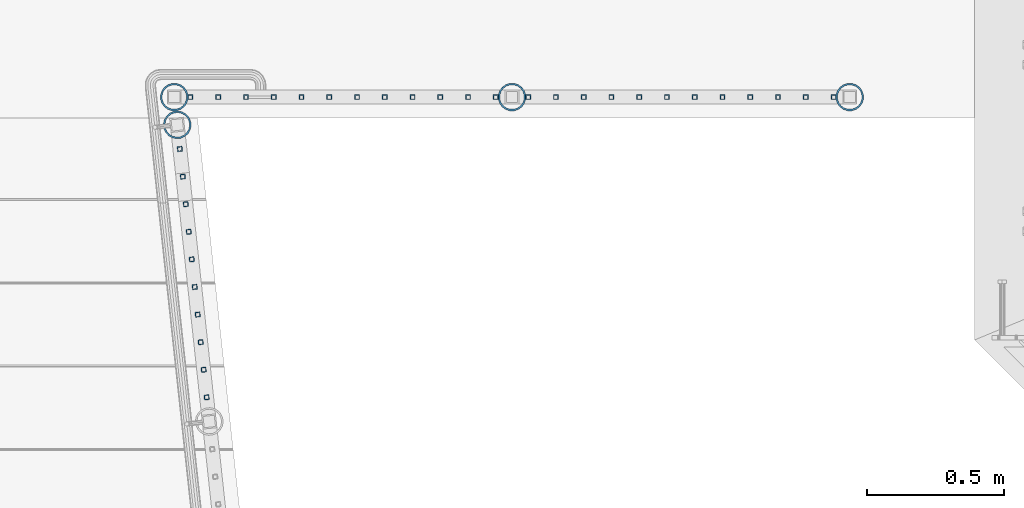
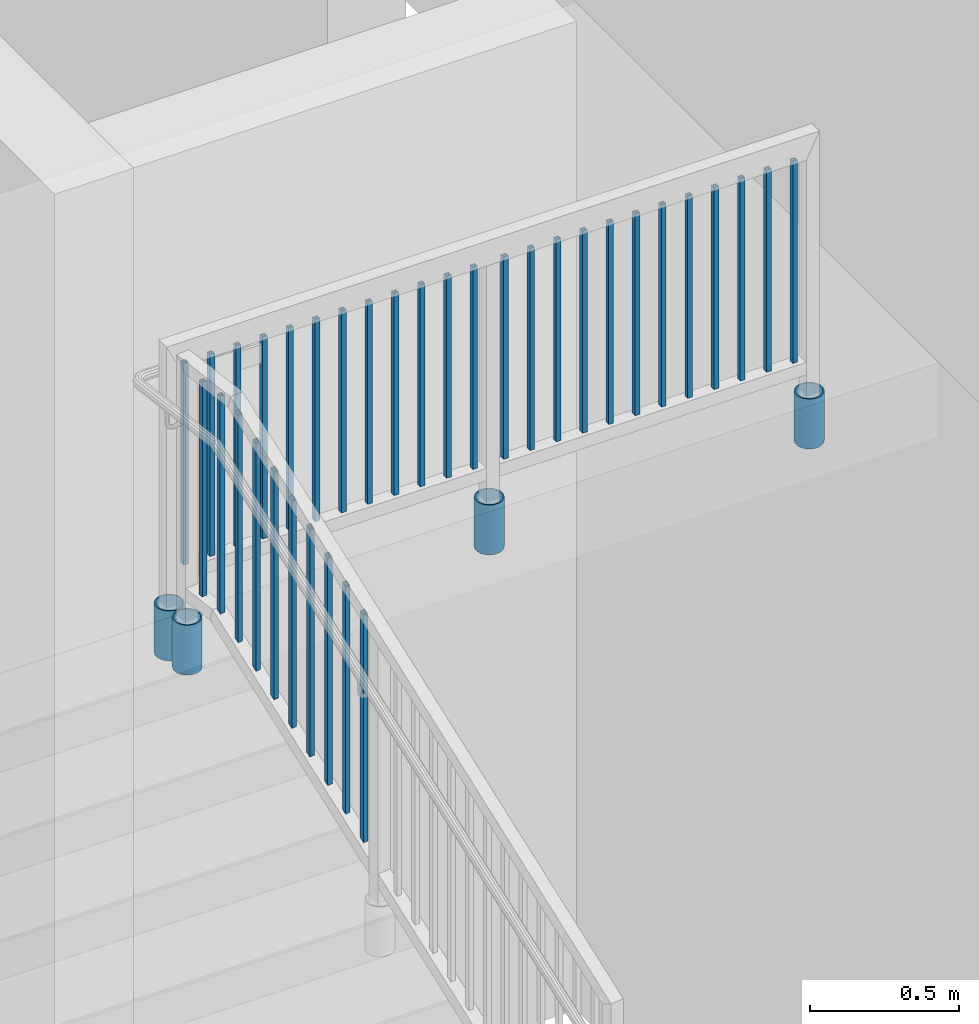
# One storey, part 142 of 975: 38 columns.
"""IFC2X3 building model written with IfcOpenShell, lengths in millimetres."""

from ifc_helpers import new_model, si_unit, frame, origin_with_axes, place, context, subcontext, project, spatial, faceted_brep, material, type_object, element, save


model = new_model("IFC2X3")

# Units and contexts
model_context = context("Model", 3, precision=1e-05, world=origin_with_axes())
body_context = subcontext(model_context, "Body", "Model", "MODEL_VIEW")
ifc_project = project(units=[si_unit("LENGTHUNIT", "METRE", prefix="MILLI"), si_unit("AREAUNIT", "SQUARE_METRE"), si_unit("VOLUMEUNIT", "CUBIC_METRE"), si_unit("MASSUNIT", "GRAM", prefix="KILO"), si_unit("TIMEUNIT", "SECOND"), si_unit("PLANEANGLEUNIT", "RADIAN"), si_unit("SOLIDANGLEUNIT", "STERADIAN"), si_unit("THERMODYNAMICTEMPERATUREUNIT", "DEGREE_CELSIUS"), si_unit("LUMINOUSINTENSITYUNIT", "LUMEN")], contexts=[model_context])

# Site, building, storey
site_placement = place(None, origin_with_axes())
site = spatial("IfcSite", under=ifc_project, at=site_placement, CompositionType="ELEMENT")
building_placement = place(site_placement, origin_with_axes())
building = spatial("IfcBuilding", under=site, at=building_placement, Name="Undefined", CompositionType="ELEMENT")
storey_placement = place(building_placement, origin_with_axes())
storey = spatial("IfcBuildingStorey", under=building, at=storey_placement, Name="Undefined", CompositionType="ELEMENT", Elevation=0.0)

# Columns
ifc_material_1 = material()
column_type_1 = type_object("IfcColumnType", Name="HSS3/4X3/4X.120_TUBES", PredefinedType="NOTDEFINED")
column_1_placement = place(storey_placement, frame((-893.043869114453, 3137.33905229593, 4203.33690920319), z_axis=(-0.107163682972125, 0.994241391741387, -1.51279482452082e-08), x_axis=(0.0, 0.0, 1.0)))
element("IfcColumn", 1, at=column_1_placement, inside=storey, type_object=column_type_1, material=ifc_material_1, Name="PICKET", ObjectType="HSS3/4X3/4X.120_TUBES", context=body_context, shape_type="Brep", body=[
    faceted_brep([(51.1631046552238, 6.34999999999991, -6.35000000000855), (51.1631046600623, -6.34999999999991, -6.35000000000855), (927.463079106175, -6.34999999999991, -6.3500000001477), (927.463079101335, 6.34999999999991, -6.3500000001477), (51.1630993403815, -6.34999999999991, 6.34999999999172), (927.463078498194, -6.34999999999991, 6.34999999985257), (51.1630993355429, 6.34999999999991, 6.34999999999172), (927.463078493354, 6.34999999999991, 6.34999999985257), (51.1631059839347, 9.52500000000009, -9.52500000000873), (51.1630980044138, 9.52500000000009, 9.52499999999191), (927.463078340149, 9.52500000000009, 9.5249999998523), (927.46307925212, 9.52500000000009, -9.52500000014743), (51.1630980116715, -9.52500000000009, 9.52499999999191), (927.463078347408, -9.52500000000009, 9.5249999998523), (51.1631059911924, -9.52500000000009, -9.52500000000873), (927.463079259379, -9.52500000000009, -9.52500000014743)], [[[0, 1, 2, 3]], [[1, 4, 5, 2]], [[4, 6, 7, 5]], [[6, 0, 3, 7]], [[8, 9, 10, 11]], [[9, 12, 13, 10]], [[12, 14, 15, 13]], [[14, 8, 11, 15]], [[13, 15, 11, 10], [5, 7, 3, 2]], [[14, 12, 9, 8], [6, 4, 1, 0]]]),
])
column_2_placement = place(storey_placement, frame((-882.156825510756, 3036.33145302633, 4203.33691042617), z_axis=(-0.107163682972125, 0.994241391741387, -1.51279482452082e-08), x_axis=(0.0, 0.0, 1.0)))
element("IfcColumn", 2, at=column_2_placement, inside=storey, type_object=column_type_1, material=ifc_material_1, Name="PICKET", ObjectType="HSS3/4X3/4X.120_TUBES", context=body_context, shape_type="Brep", body=[
    faceted_brep([(40.1041543496849, 6.34999999999991, -6.35000000000855), (40.1041545719772, -6.35000000000014, -6.35000000000628), (927.463079106175, -6.34999999999991, -6.3500000001477), (927.463079101335, 6.34999999999991, -6.3500000001477), (47.5124881750762, -6.3499999999998, 6.34999999999445), (927.463078498194, -6.34999999999991, 6.34999999985257), (47.5124879527839, 6.35000000000048, 6.34999999999309), (927.463078493354, 6.34999999999991, 6.34999999985257), (38.2520708933371, 9.52499999999975, -9.52500000000828), (49.364571297986, 9.52500000000055, 9.52499999999236), (927.463078340149, 9.52500000000009, 9.5249999998523), (927.46307925212, 9.52500000000009, -9.52500000014743), (49.364571631424, -9.52499999999964, 9.52499999999509), (927.463078347408, -9.52500000000009, 9.5249999998523), (38.2520712267751, -9.52500000000043, -9.52500000000555), (927.463079259379, -9.52500000000009, -9.52500000014743)], [[[0, 1, 2, 3]], [[1, 4, 5, 2]], [[4, 6, 7, 5]], [[6, 0, 3, 7]], [[8, 9, 10, 11]], [[9, 12, 13, 10]], [[12, 14, 15, 13]], [[14, 8, 11, 15]], [[13, 15, 11, 10], [5, 7, 3, 2]], [[14, 12, 9, 8], [6, 4, 1, 0]]]),
])
for number, where, z_axis, x_axis, name in (
    (3, (-871.269781887117, 2935.32385357171, 4187.88286216125), (-0.107163682972125, 0.994241391741387, -1.51279482452082e-08), (0.0, 0.0, 1.0), "PICKET"),
    (4, (-860.382738206991, 2834.31625359302, 4128.62049317313), (-0.107163682972125, 0.994241391741387, -1.51279482452082e-08), (0.0, 0.0, 1.0), "PICKET"),
    (5, (-849.495694526905, 2733.3086536147, 4069.35812418497), (-0.107163682972125, 0.994241391741387, -1.51279482452082e-08), (0.0, 0.0, 1.0), "PICKET"),
    (6, (-838.608650846774, 2632.30105363596, 4010.09575519681), (-0.107163682972125, 0.994241391741387, -1.51279482452082e-08), (0.0, 0.0, 1.0), "PICKET"),
    (7, (-827.721607166643, 2531.29345365722, 3950.83338620865), (-0.107163682972125, 0.994241391741387, -1.51279482452082e-08), (0.0, 0.0, 1.0), "PICKET"),
    (8, (-816.834563486512, 2430.28585367849, 3891.5710172205), (-0.107163682972125, 0.994241391741387, -1.51279482452082e-08), (0.0, 0.0, 1.0), "PICKET"),
    (9, (-805.947519806381, 2329.27825369975, 3832.30864823234), (-0.107163682972125, 0.994241391741387, -1.51279482452082e-08), (0.0, 0.0, 1.0), "PICKET"),
    (10, (-795.06047612625, 2228.27065372101, 3773.04627924418), (-0.107163682972125, 0.994241391741387, -1.51279482452082e-08), (0.0, 0.0, 1.0), "PICKET"),
):
    element("IfcColumn", number, at=place(storey_placement, frame(where, z_axis=z_axis, x_axis=x_axis)), inside=storey, type_object=column_type_1, material=ifc_material_1, Name=name, ObjectType="HSS3/4X3/4X.120_TUBES", context=body_context, shape_type="Brep", body=[
        faceted_brep([(-3.70416645998739, 6.34999999999991, -6.34999999999945), (-3.70416623769415, -6.34999999999991, -6.34999999999945), (923.75891709344, -6.34999999999991, -6.35000000014634), (923.758916871147, 6.34999999999991, -6.35000000014634), (3.70416736539664, -6.34999999999991, 6.349999999999), (931.167250696531, -6.34999999999991, 6.34999999985212), (3.70416714310431, 6.34999999999991, 6.349999999999), (931.167250474238, 6.34999999999991, 6.34999999985212), (-5.5562499163334, 9.52500000000009, -9.52499999999964), (5.5562504883037, 9.52500000000009, 9.52499999999918), (933.019333819438, 9.52500000000009, 9.5249999998523), (921.906833414801, 9.52500000000009, -9.52500000014652), (5.55625082174265, -9.52500000000009, 9.52499999999918), (933.019334152877, -9.52500000000009, 9.5249999998523), (-5.55624958289354, -9.52500000000009, -9.52499999999964), (921.90683374824, -9.52500000000009, -9.52500000014652)], [[[0, 1, 2, 3]], [[1, 4, 5, 2]], [[4, 6, 7, 5]], [[6, 0, 3, 7]], [[8, 9, 10, 11]], [[9, 12, 13, 10]], [[12, 14, 15, 13]], [[14, 8, 11, 15]], [[13, 15, 11, 10], [5, 7, 3, 2]], [[14, 12, 9, 8], [6, 4, 1, 0]]]),
    ])
for number, where, z_axis, x_axis, name in (
    (11, (1499.61038437075, 3327.40036795435, 4254.50001855985), (1.0, 0.0, 0.0), (0.0, 0.0, 1.0), "PICKET"),
    (12, (1398.01038437075, 3327.40036795435, 4254.50001855985), (1.0, 0.0, 0.0), (0.0, 0.0, 1.0), "PICKET"),
    (13, (1296.41038437075, 3327.40036795435, 4254.50001855985), (1.0, 0.0, 0.0), (0.0, 0.0, 1.0), "PICKET"),
    (14, (1194.81038437075, 3327.40036795435, 4254.50001855985), (1.0, 0.0, 0.0), (0.0, 0.0, 1.0), "PICKET"),
    (15, (1093.21038437075, 3327.40036795435, 4254.50001855985), (1.0, 0.0, 0.0), (0.0, 0.0, 1.0), "PICKET"),
    (16, (991.610384370745, 3327.40036795435, 4254.50001855985), (1.0, 0.0, 0.0), (0.0, 0.0, 1.0), "PICKET"),
    (17, (890.010384370746, 3327.40036795435, 4254.50001855985), (1.0, 0.0, 0.0), (0.0, 0.0, 1.0), "PICKET"),
    (18, (788.410384370746, 3327.40036795435, 4254.50001855985), (1.0, 0.0, 0.0), (0.0, 0.0, 1.0), "PICKET"),
    (19, (686.810384370746, 3327.40036795435, 4254.50001855985), (1.0, 0.0, 0.0), (0.0, 0.0, 1.0), "PICKET"),
    (20, (585.210384370745, 3327.40036795435, 4254.50001855985), (1.0, 0.0, 0.0), (0.0, 0.0, 1.0), "PICKET"),
    (21, (483.610384370746, 3327.40036795435, 4254.50001855985), (1.0, 0.0, 0.0), (0.0, 0.0, 1.0), "PICKET"),
    (22, (382.010384370746, 3327.40036795435, 4254.50001855985), (1.0, 0.0, 0.0), (0.0, 0.0, 1.0), "PICKET"),
    (23, (263.380990660052, 3327.40038657919, 4254.50001844122), (1.0, 0.0, 0.0), (0.0, 0.0, 1.0), "PICKET"),
    (24, (161.780990660037, 3327.40040253042, 4254.50001844122), (1.0, 0.0, 0.0), (0.0, 0.0, 1.0), "PICKET"),
    (25, (60.1809906600373, 3327.40040253042, 4254.50001844122), (1.0, 0.0, 0.0), (0.0, 0.0, 1.0), "PICKET"),
    (26, (-41.4190093399627, 3327.40040253042, 4254.50001844122), (1.0, 0.0, 0.0), (0.0, 0.0, 1.0), "PICKET"),
    (27, (-143.019009339963, 3327.40040253042, 4254.50001844122), (1.0, 0.0, 0.0), (0.0, 0.0, 1.0), "PICKET"),
    (28, (-244.619009339963, 3327.40040253042, 4254.50001844122), (1.0, 0.0, 0.0), (0.0, 0.0, 1.0), "PICKET"),
    (29, (-346.219009339963, 3327.40040253042, 4254.50001844122), (1.0, 0.0, 0.0), (0.0, 0.0, 1.0), "PICKET"),
    (30, (-447.819009339963, 3327.40040253042, 4254.50001844122), (1.0, 0.0, 0.0), (0.0, 0.0, 1.0), "PICKET"),
    (31, (-549.419009339963, 3327.40040253042, 4254.50001844122), (1.0, 0.0, 0.0), (0.0, 0.0, 1.0), "PICKET"),
    (32, (-651.019009339963, 3327.40040253042, 4254.50001844122), (1.0, 0.0, 0.0), (0.0, 0.0, 1.0), "PICKET"),
    (33, (-752.619009339963, 3327.40040253042, 4254.50001844122), (1.0, 0.0, 0.0), (0.0, 0.0, 1.0), "PICKET"),
    (34, (-854.219009339963, 3327.40040253042, 4254.50001844122), (1.0, 0.0, 0.0), (0.0, 0.0, 1.0), "PICKET"),
):
    element("IfcColumn", number, at=place(storey_placement, frame(where, z_axis=z_axis, x_axis=x_axis)), inside=storey, type_object=column_type_1, material=ifc_material_1, Name=name, ObjectType="HSS3/4X3/4X.120_TUBES", context=body_context, shape_type="Brep", body=[
        faceted_brep([(0.0, 6.34999999998763, -6.34999999998763), (0.0, -6.35000000000582, -6.34999999998763), (825.49997943247, -6.35000000000582, -6.34999999998763), (825.49997943247, 6.34999999998763, -6.34999999998763), (0.0, -6.34999999998763, 6.34999999998763), (825.49997943247, -6.34999999998763, 6.34999999998763), (0.0, 6.35000000000946, 6.34999999998763), (825.49997943247, 6.35000000000946, 6.34999999998763), (0.0, 9.52499999997963, -9.52499999997963), (0.0, 9.52500000000873, 9.5249999999869), (825.49997943247, 9.52500000000873, 9.5249999999869), (825.49997943247, 9.52499999997963, -9.52499999997963), (0.0, -9.52499999997963, 9.52499999998327), (825.49997943247, -9.52499999997963, 9.52499999998327), (0.0, -9.52500000000873, -9.5249999999869), (825.49997943247, -9.52500000000873, -9.5249999999869)], [[[0, 1, 2, 3]], [[1, 4, 5, 2]], [[4, 6, 7, 5]], [[6, 0, 3, 7]], [[8, 9, 10, 11]], [[9, 12, 13, 10]], [[12, 14, 15, 13]], [[14, 8, 11, 15]], [[13, 15, 11, 10], [5, 7, 3, 2]], [[14, 12, 9, 8], [6, 4, 1, 0]]]),
    ])
ifc_material_2 = material(Name="STEEL/A53")
column_type_2 = type_object("IfcColumnType", Name="PIPE3-1/2STD", PredefinedType="NOTDEFINED")
column_3_placement = place(storey_placement, frame((-902.57861743711, 3225.80035230631, 3911.59996494345), z_axis=(-0.778811015080024, 0.627258641064452, -9.08472520677606e-09), x_axis=(0.0, 0.0, 1.0)))
element("IfcColumn", 35, at=column_3_placement, inside=storey, type_object=column_type_2, material=ifc_material_2, ObjectType="PIPE3-1/2STD", context=body_context, shape_type="Brep", body=[
    faceted_brep([(0.0, -45.0595999999932, 1.45519152283669e-11), (0.0, -42.8542262016344, 13.924182159768), (203.199999999991, -42.8542262017145, 13.9241821598171), (203.19999999999, -45.0596000000478, 5.82076609134674e-11), (0.0, -36.45398215971, 26.4853683542424), (203.199999999993, -36.45398215981, 26.4853683542988), (0.0, -26.4853683541623, 36.45398215979), (203.199999999995, -26.4853683542788, 36.4539821598537), (0.0, -13.9241821596988, 42.8542262017108), (203.199999999998, -13.9241821598262, 42.8542262017836), (0.0, 3.63797880709171e-11, 45.0596000000514), (203.2, -9.27684595808387e-11, 45.0596000001387), (0.0, 13.9241821597716, 42.8542262017036), (203.200000000003, 13.9241821596443, 42.8542262017927), (0.0, 26.4853683542242, 36.4539821597718), (203.200000000006, 26.4853683541096, 36.4539821598701), (0.0, 36.4539821597537, 26.4853683542206), (203.200000000008, 36.4539821596554, 26.4853683543224), (0.0, 42.8542262016563, 13.9241821597425), (203.200000000009, 42.8542262015817, 13.9241821598443), (0.0, 45.0595999999932, -1.09139364212751e-11), (203.200000000009, 45.0595999999423, 8.9130480773747e-11), (0.0, 42.8542262016344, -13.9241821597643), (203.200000000008, 42.854226201609, -13.9241821596697), (0.0, 36.45398215971, -26.4853683542387), (203.200000000007, 36.4539821597045, -26.4853683541514), (0.0, 26.4853683541623, -36.4539821597864), (203.200000000004, 26.4853683541733, -36.4539821597064), (0.0, 13.9241821596988, -42.8542262017072), (203.200000000002, 13.9241821597225, -42.8542262016381), (0.0, -3.63797880709171e-11, -45.0596000000478), (203.199999999999, -9.09494701772928e-12, -45.0595999999914), (0.0, -13.9241821597716, -42.8542262016963), (203.199999999996, -13.9241821597479, -42.8542262016472), (0.0, -26.4853683542242, -36.4539821597682), (203.199999999993, -26.4853683542133, -36.4539821597227), (0.0, -36.4539821597537, -26.4853683542169), (203.199999999992, -36.4539821597609, -26.4853683541751), (0.0, -42.8542262016563, -13.9241821597352), (203.199999999991, -42.8542262016872, -13.924182159697), (0.0, -50.799999999992, 1.81898940354586e-11), (0.0, -48.3136710278013, -15.6980633142484), (203.199999999989, -48.313671027825, -15.6980633142139), (203.199999999989, -50.8000000000466, 5.63886715099216e-11), (0.0, -41.0980633142644, -29.8594908164741), (203.19999999999, -41.0980633142663, -29.8594908164414), (0.0, -29.859490816485, -41.0980633142826), (203.199999999993, -29.8594908164687, -41.0980633142426), (0.0, -15.6980633142848, -48.313671027845), (203.199999999995, -15.6980633142539, -48.313671027794), (0.0, -4.36557456851006e-11, -50.8000000000575), (203.199999999998, -7.27595761418343e-12, -50.7999999999993), (0.0, 15.6980633142011, -48.3136710278523), (203.200000000002, 15.6980633142375, -48.3136710277831), (0.0, 29.8594908164159, -41.0980633143045), (203.200000000005, 29.8594908164378, -41.0980633142226), (0.0, 41.0980633142135, -29.8594908165032), (203.200000000008, 41.0980633142171, -29.8594908164141), (0.0, 48.3136710277722, -15.6980633142775), (203.200000000009, 48.3136710277504, -15.6980633141811), (0.0, 50.799999999992, -1.45519152283669e-11), (203.20000000001, 50.7999999999411, 9.09494701772928e-11), (0.0, 48.313671027794, 15.6980633142521), (203.20000000001, 48.3136710277213, 15.6980633143594), (0.0, 41.0980633142644, 29.8594908164814), (203.200000000008, 41.0980633141626, 29.8594908165887), (0.0, 29.859490816485, 41.0980633142863), (203.200000000007, 29.8594908163632, 41.0980633143899), (0.0, 15.6980633142848, 48.3136710278486), (203.200000000004, 15.6980633141484, 48.3136710279414), (0.0, 4.00177668780088e-11, 50.8000000000611), (203.200000000001, -9.82254277914762e-11, 50.8000000001466), (0.0, -15.6980633142011, 48.3136710278559), (203.199999999997, -15.698063314343, 48.3136710279305), (0.0, -29.8594908164159, 41.0980633143081), (203.199999999994, -29.8594908165433, 41.0980633143681), (0.0, -41.0980633142171, 29.8594908165069), (203.199999999992, -41.0980633143226, 29.8594908165596), (0.0, -48.3136710277722, 15.6980633142812), (203.19999999999, -48.3136710278559, 15.6980633143285)], [[[0, 1, 2, 3]], [[1, 4, 5, 2]], [[4, 6, 7, 5]], [[6, 8, 9, 7]], [[8, 10, 11, 9]], [[10, 12, 13, 11]], [[12, 14, 15, 13]], [[14, 16, 17, 15]], [[16, 18, 19, 17]], [[18, 20, 21, 19]], [[20, 22, 23, 21]], [[22, 24, 25, 23]], [[24, 26, 27, 25]], [[26, 28, 29, 27]], [[28, 30, 31, 29]], [[30, 32, 33, 31]], [[32, 34, 35, 33]], [[34, 36, 37, 35]], [[36, 38, 39, 37]], [[38, 0, 3, 39]], [[40, 41, 42, 43]], [[41, 44, 45, 42]], [[44, 46, 47, 45]], [[46, 48, 49, 47]], [[48, 50, 51, 49]], [[50, 52, 53, 51]], [[52, 54, 55, 53]], [[54, 56, 57, 55]], [[56, 58, 59, 57]], [[58, 60, 61, 59]], [[60, 62, 63, 61]], [[62, 64, 65, 63]], [[64, 66, 67, 65]], [[66, 68, 69, 67]], [[68, 70, 71, 69]], [[70, 72, 73, 71]], [[72, 74, 75, 73]], [[74, 76, 77, 75]], [[76, 78, 79, 77]], [[78, 40, 43, 79]], [[45, 47, 49, 51, 53, 55, 57, 59, 61, 63, 65, 67, 69, 71, 73, 75, 77, 79, 43, 42], [5, 7, 9, 11, 13, 15, 17, 19, 21, 23, 25, 27, 29, 31, 33, 35, 37, 39, 3, 2]], [[78, 76, 74, 72, 70, 68, 66, 64, 62, 60, 58, 56, 54, 52, 50, 48, 46, 44, 41, 40], [38, 36, 34, 32, 30, 28, 26, 24, 22, 20, 18, 16, 14, 12, 10, 8, 6, 4, 1, 0]]]),
])
column_4_placement = place(storey_placement, frame((1558.92499396022, 3327.43642318416, 3911.60001649977), z_axis=(-0.707106781186601, 0.707106781186494, 2.36468622460961e-14), x_axis=(0.0, 0.0, 1.0)))
element("IfcColumn", 36, at=column_4_placement, inside=storey, type_object=column_type_2, material=ifc_material_2, ObjectType="PIPE3-1/2STD", context=body_context, shape_type="Brep", body=[
    faceted_brep([(0.0, -45.0595999999932, 1.45519152283669e-11), (0.0, -42.8542262016344, 13.924182159768), (203.199999999991, -42.8542262017145, 13.9241821598171), (203.19999999999, -45.0596000000478, 5.82076609134674e-11), (0.0, -36.45398215971, 26.4853683542424), (203.199999999993, -36.45398215981, 26.4853683542988), (0.0, -26.4853683541623, 36.45398215979), (203.199999999995, -26.4853683542788, 36.4539821598537), (0.0, -13.9241821596988, 42.8542262017108), (203.199999999998, -13.9241821598262, 42.8542262017836), (0.0, 3.63797880709171e-11, 45.0596000000514), (203.2, -9.27684595808387e-11, 45.0596000001387), (0.0, 13.9241821597716, 42.8542262017036), (203.200000000003, 13.9241821596443, 42.8542262017927), (0.0, 26.4853683542242, 36.4539821597718), (203.200000000006, 26.4853683541096, 36.4539821598701), (0.0, 36.4539821597537, 26.4853683542206), (203.200000000008, 36.4539821596554, 26.4853683543224), (0.0, 42.8542262016563, 13.9241821597425), (203.200000000009, 42.8542262015817, 13.9241821598443), (0.0, 45.0595999999932, -1.09139364212751e-11), (203.200000000009, 45.0595999999423, 8.9130480773747e-11), (0.0, 42.8542262016344, -13.9241821597643), (203.200000000008, 42.854226201609, -13.9241821596697), (0.0, 36.45398215971, -26.4853683542387), (203.200000000007, 36.4539821597045, -26.4853683541514), (0.0, 26.4853683541623, -36.4539821597864), (203.200000000004, 26.4853683541733, -36.4539821597064), (0.0, 13.9241821596988, -42.8542262017072), (203.200000000002, 13.9241821597225, -42.8542262016381), (0.0, -3.63797880709171e-11, -45.0596000000478), (203.199999999999, -9.09494701772928e-12, -45.0595999999914), (0.0, -13.9241821597716, -42.8542262016963), (203.199999999996, -13.9241821597479, -42.8542262016472), (0.0, -26.4853683542242, -36.4539821597682), (203.199999999993, -26.4853683542133, -36.4539821597227), (0.0, -36.4539821597537, -26.4853683542169), (203.199999999992, -36.4539821597609, -26.4853683541751), (0.0, -42.8542262016563, -13.9241821597352), (203.199999999991, -42.8542262016872, -13.924182159697), (0.0, -50.799999999992, 1.81898940354586e-11), (0.0, -48.3136710278013, -15.6980633142484), (203.199999999989, -48.313671027825, -15.6980633142139), (203.199999999989, -50.8000000000466, 5.63886715099216e-11), (0.0, -41.0980633142644, -29.8594908164741), (203.19999999999, -41.0980633142663, -29.8594908164414), (0.0, -29.859490816485, -41.0980633142826), (203.199999999993, -29.8594908164687, -41.0980633142426), (0.0, -15.6980633142848, -48.313671027845), (203.199999999995, -15.6980633142539, -48.313671027794), (0.0, -4.36557456851006e-11, -50.8000000000575), (203.199999999998, -7.27595761418343e-12, -50.7999999999993), (0.0, 15.6980633142011, -48.3136710278523), (203.200000000002, 15.6980633142375, -48.3136710277831), (0.0, 29.8594908164159, -41.0980633143045), (203.200000000005, 29.8594908164378, -41.0980633142226), (0.0, 41.0980633142135, -29.8594908165032), (203.200000000008, 41.0980633142171, -29.8594908164141), (0.0, 48.3136710277722, -15.6980633142775), (203.200000000009, 48.3136710277504, -15.6980633141811), (0.0, 50.799999999992, -1.45519152283669e-11), (203.20000000001, 50.7999999999411, 9.09494701772928e-11), (0.0, 48.313671027794, 15.6980633142521), (203.20000000001, 48.3136710277213, 15.6980633143594), (0.0, 41.0980633142644, 29.8594908164814), (203.200000000008, 41.0980633141626, 29.8594908165887), (0.0, 29.859490816485, 41.0980633142863), (203.200000000007, 29.8594908163632, 41.0980633143899), (0.0, 15.6980633142848, 48.3136710278486), (203.200000000004, 15.6980633141484, 48.3136710279414), (0.0, 4.00177668780088e-11, 50.8000000000611), (203.200000000001, -9.82254277914762e-11, 50.8000000001466), (0.0, -15.6980633142011, 48.3136710278559), (203.199999999997, -15.698063314343, 48.3136710279305), (0.0, -29.8594908164159, 41.0980633143081), (203.199999999994, -29.8594908165433, 41.0980633143681), (0.0, -41.0980633142171, 29.8594908165069), (203.199999999992, -41.0980633143226, 29.8594908165596), (0.0, -48.3136710277722, 15.6980633142812), (203.19999999999, -48.3136710278559, 15.6980633143285)], [[[0, 1, 2, 3]], [[1, 4, 5, 2]], [[4, 6, 7, 5]], [[6, 8, 9, 7]], [[8, 10, 11, 9]], [[10, 12, 13, 11]], [[12, 14, 15, 13]], [[14, 16, 17, 15]], [[16, 18, 19, 17]], [[18, 20, 21, 19]], [[20, 22, 23, 21]], [[22, 24, 25, 23]], [[24, 26, 27, 25]], [[26, 28, 29, 27]], [[28, 30, 31, 29]], [[30, 32, 33, 31]], [[32, 34, 35, 33]], [[34, 36, 37, 35]], [[36, 38, 39, 37]], [[38, 0, 3, 39]], [[40, 41, 42, 43]], [[41, 44, 45, 42]], [[44, 46, 47, 45]], [[46, 48, 49, 47]], [[48, 50, 51, 49]], [[50, 52, 53, 51]], [[52, 54, 55, 53]], [[54, 56, 57, 55]], [[56, 58, 59, 57]], [[58, 60, 61, 59]], [[60, 62, 63, 61]], [[62, 64, 65, 63]], [[64, 66, 67, 65]], [[66, 68, 69, 67]], [[68, 70, 71, 69]], [[70, 72, 73, 71]], [[72, 74, 75, 73]], [[74, 76, 77, 75]], [[76, 78, 79, 77]], [[78, 40, 43, 79]], [[45, 47, 49, 51, 53, 55, 57, 59, 61, 63, 65, 67, 69, 71, 73, 75, 77, 79, 43, 42], [5, 7, 9, 11, 13, 15, 17, 19, 21, 23, 25, 27, 29, 31, 33, 35, 37, 39, 3, 2]], [[78, 76, 74, 72, 70, 68, 66, 64, 62, 60, 58, 56, 54, 52, 50, 48, 46, 44, 41, 40], [38, 36, 34, 32, 30, 28, 26, 24, 22, 20, 18, 16, 14, 12, 10, 8, 6, 4, 1, 0]]]),
])
column_5_placement = place(storey_placement, frame((322.695797111396, 3327.40039056697, 3911.60001649977), z_axis=(-0.707106781186601, 0.707106781186494, 2.36468622460961e-14), x_axis=(0.0, 0.0, 1.0)))
element("IfcColumn", 37, at=column_5_placement, inside=storey, type_object=column_type_2, material=ifc_material_2, ObjectType="PIPE3-1/2STD", context=body_context, shape_type="Brep", body=[
    faceted_brep([(0.0, -45.0595999999932, 1.45519152283669e-11), (0.0, -42.8542262016344, 13.924182159768), (203.199999999991, -42.8542262017145, 13.9241821598171), (203.19999999999, -45.0596000000478, 5.82076609134674e-11), (0.0, -36.45398215971, 26.4853683542424), (203.199999999993, -36.45398215981, 26.4853683542988), (0.0, -26.4853683541623, 36.45398215979), (203.199999999995, -26.4853683542788, 36.4539821598537), (0.0, -13.9241821596988, 42.8542262017108), (203.199999999998, -13.9241821598262, 42.8542262017836), (0.0, 3.63797880709171e-11, 45.0596000000514), (203.2, -9.27684595808387e-11, 45.0596000001387), (0.0, 13.9241821597716, 42.8542262017036), (203.200000000003, 13.9241821596443, 42.8542262017927), (0.0, 26.4853683542242, 36.4539821597718), (203.200000000006, 26.4853683541096, 36.4539821598701), (0.0, 36.4539821597537, 26.4853683542206), (203.200000000008, 36.4539821596554, 26.4853683543224), (0.0, 42.8542262016563, 13.9241821597425), (203.200000000009, 42.8542262015817, 13.9241821598443), (0.0, 45.0595999999932, -1.09139364212751e-11), (203.200000000009, 45.0595999999423, 8.9130480773747e-11), (0.0, 42.8542262016344, -13.9241821597643), (203.200000000008, 42.854226201609, -13.9241821596697), (0.0, 36.45398215971, -26.4853683542387), (203.200000000007, 36.4539821597045, -26.4853683541514), (0.0, 26.4853683541623, -36.4539821597864), (203.200000000004, 26.4853683541733, -36.4539821597064), (0.0, 13.9241821596988, -42.8542262017072), (203.200000000002, 13.9241821597225, -42.8542262016381), (0.0, -3.63797880709171e-11, -45.0596000000478), (203.199999999999, -9.09494701772928e-12, -45.0595999999914), (0.0, -13.9241821597716, -42.8542262016963), (203.199999999996, -13.9241821597479, -42.8542262016472), (0.0, -26.4853683542242, -36.4539821597682), (203.199999999993, -26.4853683542133, -36.4539821597227), (0.0, -36.4539821597537, -26.4853683542169), (203.199999999992, -36.4539821597609, -26.4853683541751), (0.0, -42.8542262016563, -13.9241821597352), (203.199999999991, -42.8542262016872, -13.924182159697), (0.0, -50.799999999992, 1.81898940354586e-11), (0.0, -48.3136710278013, -15.6980633142484), (203.199999999989, -48.313671027825, -15.6980633142139), (203.199999999989, -50.8000000000466, 5.63886715099216e-11), (0.0, -41.0980633142644, -29.8594908164741), (203.19999999999, -41.0980633142663, -29.8594908164414), (0.0, -29.859490816485, -41.0980633142826), (203.199999999993, -29.8594908164687, -41.0980633142426), (0.0, -15.6980633142848, -48.313671027845), (203.199999999995, -15.6980633142539, -48.313671027794), (0.0, -4.36557456851006e-11, -50.8000000000575), (203.199999999998, -7.27595761418343e-12, -50.7999999999993), (0.0, 15.6980633142011, -48.3136710278523), (203.200000000002, 15.6980633142375, -48.3136710277831), (0.0, 29.8594908164159, -41.0980633143045), (203.200000000005, 29.8594908164378, -41.0980633142226), (0.0, 41.0980633142135, -29.8594908165032), (203.200000000008, 41.0980633142171, -29.8594908164141), (0.0, 48.3136710277722, -15.6980633142775), (203.200000000009, 48.3136710277504, -15.6980633141811), (0.0, 50.799999999992, -1.45519152283669e-11), (203.20000000001, 50.7999999999411, 9.09494701772928e-11), (0.0, 48.313671027794, 15.6980633142521), (203.20000000001, 48.3136710277213, 15.6980633143594), (0.0, 41.0980633142644, 29.8594908164814), (203.200000000008, 41.0980633141626, 29.8594908165887), (0.0, 29.859490816485, 41.0980633142863), (203.200000000007, 29.8594908163632, 41.0980633143899), (0.0, 15.6980633142848, 48.3136710278486), (203.200000000004, 15.6980633141484, 48.3136710279414), (0.0, 4.00177668780088e-11, 50.8000000000611), (203.200000000001, -9.82254277914762e-11, 50.8000000001466), (0.0, -15.6980633142011, 48.3136710278559), (203.199999999997, -15.698063314343, 48.3136710279305), (0.0, -29.8594908164159, 41.0980633143081), (203.199999999994, -29.8594908165433, 41.0980633143681), (0.0, -41.0980633142171, 29.8594908165069), (203.199999999992, -41.0980633143226, 29.8594908165596), (0.0, -48.3136710277722, 15.6980633142812), (203.19999999999, -48.3136710278559, 15.6980633143285)], [[[0, 1, 2, 3]], [[1, 4, 5, 2]], [[4, 6, 7, 5]], [[6, 8, 9, 7]], [[8, 10, 11, 9]], [[10, 12, 13, 11]], [[12, 14, 15, 13]], [[14, 16, 17, 15]], [[16, 18, 19, 17]], [[18, 20, 21, 19]], [[20, 22, 23, 21]], [[22, 24, 25, 23]], [[24, 26, 27, 25]], [[26, 28, 29, 27]], [[28, 30, 31, 29]], [[30, 32, 33, 31]], [[32, 34, 35, 33]], [[34, 36, 37, 35]], [[36, 38, 39, 37]], [[38, 0, 3, 39]], [[40, 41, 42, 43]], [[41, 44, 45, 42]], [[44, 46, 47, 45]], [[46, 48, 49, 47]], [[48, 50, 51, 49]], [[50, 52, 53, 51]], [[52, 54, 55, 53]], [[54, 56, 57, 55]], [[56, 58, 59, 57]], [[58, 60, 61, 59]], [[60, 62, 63, 61]], [[62, 64, 65, 63]], [[64, 66, 67, 65]], [[66, 68, 69, 67]], [[68, 70, 71, 69]], [[70, 72, 73, 71]], [[72, 74, 75, 73]], [[74, 76, 77, 75]], [[76, 78, 79, 77]], [[78, 40, 43, 79]], [[45, 47, 49, 51, 53, 55, 57, 59, 61, 63, 65, 67, 69, 71, 73, 75, 77, 79, 43, 42], [5, 7, 9, 11, 13, 15, 17, 19, 21, 23, 25, 27, 29, 31, 33, 35, 37, 39, 3, 2]], [[78, 76, 74, 72, 70, 68, 66, 64, 62, 60, 58, 56, 54, 52, 50, 48, 46, 44, 41, 40], [38, 36, 34, 32, 30, 28, 26, 24, 22, 20, 18, 16, 14, 12, 10, 8, 6, 4, 1, 0]]]),
])
column_6_placement = place(storey_placement, frame((-913.533791529012, 3327.43681221011, 3911.60001649977), z_axis=(-0.707106781186601, 0.707106781186494, 2.36468622460961e-14), x_axis=(0.0, 0.0, 1.0)))
element("IfcColumn", 38, at=column_6_placement, inside=storey, type_object=column_type_2, material=ifc_material_2, ObjectType="PIPE3-1/2STD", context=body_context, shape_type="Brep", body=[
    faceted_brep([(0.0, -45.0595999999932, 1.45519152283669e-11), (0.0, -42.8542262016344, 13.924182159768), (203.199999999991, -42.8542262017145, 13.9241821598171), (203.19999999999, -45.0596000000478, 5.82076609134674e-11), (0.0, -36.45398215971, 26.4853683542424), (203.199999999993, -36.45398215981, 26.4853683542988), (0.0, -26.4853683541623, 36.45398215979), (203.199999999995, -26.4853683542788, 36.4539821598537), (0.0, -13.9241821596988, 42.8542262017108), (203.199999999998, -13.9241821598262, 42.8542262017836), (0.0, 3.63797880709171e-11, 45.0596000000514), (203.2, -9.27684595808387e-11, 45.0596000001387), (0.0, 13.9241821597716, 42.8542262017036), (203.200000000003, 13.9241821596443, 42.8542262017927), (0.0, 26.4853683542242, 36.4539821597718), (203.200000000006, 26.4853683541096, 36.4539821598701), (0.0, 36.4539821597537, 26.4853683542206), (203.200000000008, 36.4539821596554, 26.4853683543224), (0.0, 42.8542262016563, 13.9241821597425), (203.200000000009, 42.8542262015817, 13.9241821598443), (0.0, 45.0595999999932, -1.09139364212751e-11), (203.200000000009, 45.0595999999423, 8.9130480773747e-11), (0.0, 42.8542262016344, -13.9241821597643), (203.200000000008, 42.854226201609, -13.9241821596697), (0.0, 36.45398215971, -26.4853683542387), (203.200000000007, 36.4539821597045, -26.4853683541514), (0.0, 26.4853683541623, -36.4539821597864), (203.200000000004, 26.4853683541733, -36.4539821597064), (0.0, 13.9241821596988, -42.8542262017072), (203.200000000002, 13.9241821597225, -42.8542262016381), (0.0, -3.63797880709171e-11, -45.0596000000478), (203.199999999999, -9.09494701772928e-12, -45.0595999999914), (0.0, -13.9241821597716, -42.8542262016963), (203.199999999996, -13.9241821597479, -42.8542262016472), (0.0, -26.4853683542242, -36.4539821597682), (203.199999999993, -26.4853683542133, -36.4539821597227), (0.0, -36.4539821597537, -26.4853683542169), (203.199999999992, -36.4539821597609, -26.4853683541751), (0.0, -42.8542262016563, -13.9241821597352), (203.199999999991, -42.8542262016872, -13.924182159697), (0.0, -50.799999999992, 1.81898940354586e-11), (0.0, -48.3136710278013, -15.6980633142484), (203.199999999989, -48.313671027825, -15.6980633142139), (203.199999999989, -50.8000000000466, 5.63886715099216e-11), (0.0, -41.0980633142644, -29.8594908164741), (203.19999999999, -41.0980633142663, -29.8594908164414), (0.0, -29.859490816485, -41.0980633142826), (203.199999999993, -29.8594908164687, -41.0980633142426), (0.0, -15.6980633142848, -48.313671027845), (203.199999999995, -15.6980633142539, -48.313671027794), (0.0, -4.36557456851006e-11, -50.8000000000575), (203.199999999998, -7.27595761418343e-12, -50.7999999999993), (0.0, 15.6980633142011, -48.3136710278523), (203.200000000002, 15.6980633142375, -48.3136710277831), (0.0, 29.8594908164159, -41.0980633143045), (203.200000000005, 29.8594908164378, -41.0980633142226), (0.0, 41.0980633142135, -29.8594908165032), (203.200000000008, 41.0980633142171, -29.8594908164141), (0.0, 48.3136710277722, -15.6980633142775), (203.200000000009, 48.3136710277504, -15.6980633141811), (0.0, 50.799999999992, -1.45519152283669e-11), (203.20000000001, 50.7999999999411, 9.09494701772928e-11), (0.0, 48.313671027794, 15.6980633142521), (203.20000000001, 48.3136710277213, 15.6980633143594), (0.0, 41.0980633142644, 29.8594908164814), (203.200000000008, 41.0980633141626, 29.8594908165887), (0.0, 29.859490816485, 41.0980633142863), (203.200000000007, 29.8594908163632, 41.0980633143899), (0.0, 15.6980633142848, 48.3136710278486), (203.200000000004, 15.6980633141484, 48.3136710279414), (0.0, 4.00177668780088e-11, 50.8000000000611), (203.200000000001, -9.82254277914762e-11, 50.8000000001466), (0.0, -15.6980633142011, 48.3136710278559), (203.199999999997, -15.698063314343, 48.3136710279305), (0.0, -29.8594908164159, 41.0980633143081), (203.199999999994, -29.8594908165433, 41.0980633143681), (0.0, -41.0980633142171, 29.8594908165069), (203.199999999992, -41.0980633143226, 29.8594908165596), (0.0, -48.3136710277722, 15.6980633142812), (203.19999999999, -48.3136710278559, 15.6980633143285)], [[[0, 1, 2, 3]], [[1, 4, 5, 2]], [[4, 6, 7, 5]], [[6, 8, 9, 7]], [[8, 10, 11, 9]], [[10, 12, 13, 11]], [[12, 14, 15, 13]], [[14, 16, 17, 15]], [[16, 18, 19, 17]], [[18, 20, 21, 19]], [[20, 22, 23, 21]], [[22, 24, 25, 23]], [[24, 26, 27, 25]], [[26, 28, 29, 27]], [[28, 30, 31, 29]], [[30, 32, 33, 31]], [[32, 34, 35, 33]], [[34, 36, 37, 35]], [[36, 38, 39, 37]], [[38, 0, 3, 39]], [[40, 41, 42, 43]], [[41, 44, 45, 42]], [[44, 46, 47, 45]], [[46, 48, 49, 47]], [[48, 50, 51, 49]], [[50, 52, 53, 51]], [[52, 54, 55, 53]], [[54, 56, 57, 55]], [[56, 58, 59, 57]], [[58, 60, 61, 59]], [[60, 62, 63, 61]], [[62, 64, 65, 63]], [[64, 66, 67, 65]], [[66, 68, 69, 67]], [[68, 70, 71, 69]], [[70, 72, 73, 71]], [[72, 74, 75, 73]], [[74, 76, 77, 75]], [[76, 78, 79, 77]], [[78, 40, 43, 79]], [[45, 47, 49, 51, 53, 55, 57, 59, 61, 63, 65, 67, 69, 71, 73, 75, 77, 79, 43, 42], [5, 7, 9, 11, 13, 15, 17, 19, 21, 23, 25, 27, 29, 31, 33, 35, 37, 39, 3, 2]], [[78, 76, 74, 72, 70, 68, 66, 64, 62, 60, 58, 56, 54, 52, 50, 48, 46, 44, 41, 40], [38, 36, 34, 32, 30, 28, 26, 24, 22, 20, 18, 16, 14, 12, 10, 8, 6, 4, 1, 0]]]),
])

save(model, "model.ifc")
